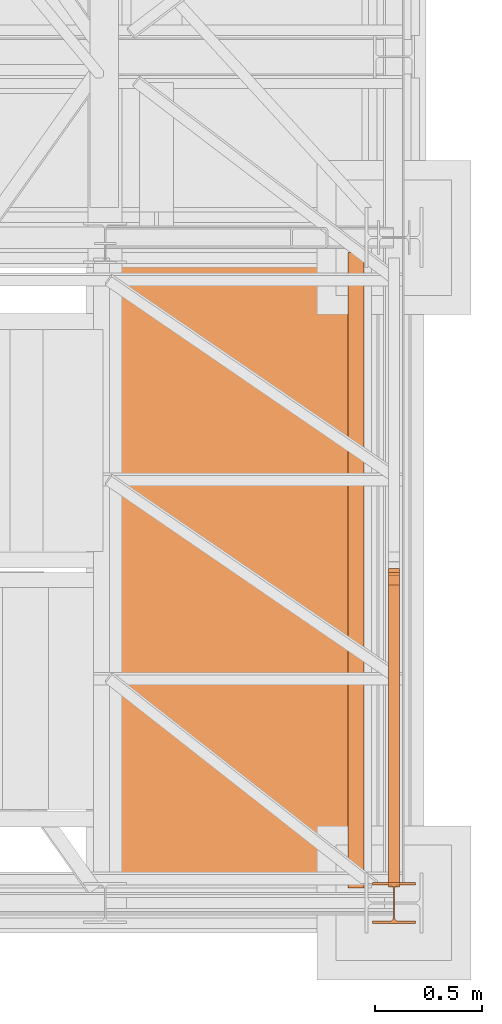
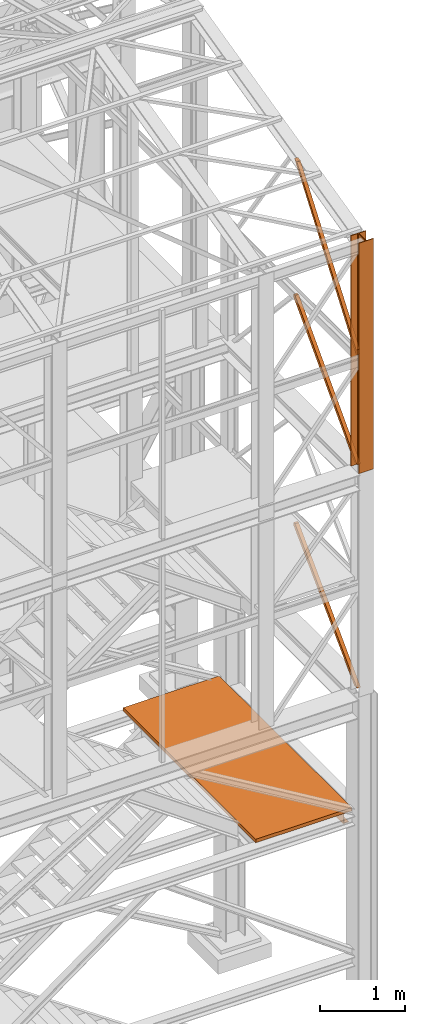
# One storey, part 50 of 208: 8 proxies.
"""IFC2X3 building model written with IfcOpenShell, lengths in millimetres."""

from ifc_helpers import new_model, entity, si_unit, converted_unit, frame, origin, origin_with_axes, place, context, subcontext, project, spatial, faceted_brep, element, save


model = new_model("IFC2X3")

# Units and contexts
model_context = context("Model", 3, precision=1e-05, world=origin())
plan_context = context("Plan", 3, precision=1e-05, world=origin())
body_context = subcontext(model_context, "Body", "Model", "MODEL_VIEW")
ifc_project = project(units=[si_unit("LENGTHUNIT", "METRE", prefix="MILLI"), converted_unit("PLANEANGLEUNIT", "DEGREE", entity("IfcPlaneAngleMeasure", 0.0174532925199433), si_unit("PLANEANGLEUNIT", "RADIAN"), dimensions=[0, 0, 0, 0, 0, 0, 0]), si_unit("AREAUNIT", "SQUARE_METRE"), si_unit("VOLUMEUNIT", "CUBIC_METRE")], contexts=[model_context, plan_context])

# Building, storey
building_placement = place(None, origin())
building = spatial("IfcBuilding", under=ifc_project, at=building_placement, CompositionType="COMPLEX")
storey_placement = place(building_placement, origin_with_axes())
storey = spatial("IfcBuildingStorey", under=building, at=storey_placement, Name="Geschoss", CompositionType="ELEMENT")

# Proxies
proxy_1_placement = place(storey_placement, frame((6483.739101185618, -25102.57439001986, 3413.989998509884), z_axis=(0.0, 0.0, 1.0), x_axis=(1.0, 0.0, 0.0)))
element("IfcBuildingElementProxy", 1, at=proxy_1_placement, inside=storey, context=body_context, shape_type="Brep", body=[
    faceted_brep([(0.01000000000021828, 2970.009999403952, 200.0100029802325), (0.01000000000021828, 2970.009999403952, 0.01000000000021828), (75.01000111758731, 2970.009999403952, 0.01000000000021828), (75.01000111758731, 2970.009999403952, 2.97083092689536), (73.89400100171588, 2970.009999403952, 7.368834147453526), (69.48847269475482, 2970.009999403952, 8.951724896431188), (19.09293180167697, 2970.009999403952, 12.98336816787742), (13.35380079060815, 2970.009999403952, 14.57858962774299), (9.50015002697728, 2970.009999403952, 18.85888857603095), (8.510000461936215, 2970.009999403952, 24.44674206733725), (8.510000461936215, 2970.009999403952, 175.5732609128954), (9.50015002697728, 2970.009999403952, 181.1611144042017), (13.35380079060815, 2970.009999403952, 185.4414133524897), (19.09293180167697, 2970.009999403952, 187.0366348123553), (69.48847269475482, 2970.009999403952, 191.0682780838015), (73.89400100171588, 2970.009999403952, 192.6511688327792), (75.01000111758731, 2970.009999403952, 197.0491720533373), (75.01000111758731, 2970.009999403952, 200.0100029802325), (0.01000000000021828, 2970.009999403952, 0.01000000000021828), (0.01000000000021828, 2970.009999403952, 200.0100029802325), (0.01000000000021828, 0.00999999999839929, 200.0100029802325), (0.01000000000021828, 0.00999999999839929, 0.01000000000021828), (75.01000111758731, 2970.009999403952, 0.01000000000021828), (0.01000000000021828, 2970.009999403952, 0.01000000000021828), (0.01000000000021828, 0.00999999999839929, 0.01000000000021828), (75.01000111758731, 0.00999999999839929, 0.01000000000021828), (75.01000111758731, 2970.009999403952, 2.97083092689536), (75.01000111758731, 2970.009999403952, 0.01000000000021828), (75.01000111758731, 0.00999999999839929, 0.01000000000021828), (75.01000111758731, 0.00999999999839929, 2.97083092689536), (73.89400100171588, 2970.009999403952, 7.368834147453526), (75.01000111758731, 2970.009999403952, 2.97083092689536), (75.01000111758731, 0.00999999999839929, 2.97083092689536), (73.89400100171588, 0.00999999999839929, 7.368834147453526), (69.48847269475482, 2970.009999403952, 8.951724896431188), (73.89400100171588, 2970.009999403952, 7.368834147453526), (73.89400100171588, 0.00999999999839929, 7.368834147453526), (69.48847269475482, 0.00999999999839929, 8.951724896431188), (19.09293180167697, 2970.009999403952, 12.98336816787742), (69.48847269475482, 2970.009999403952, 8.951724896431188), (69.48847269475482, 0.00999999999839929, 8.951724896431188), (19.09293180167697, 0.00999999999839929, 12.98336816787742), (13.35380079060815, 2970.009999403952, 14.57858962774299), (19.09293180167697, 2970.009999403952, 12.98336816787742), (19.09293180167697, 0.00999999999839929, 12.98336816787742), (13.35380079060815, 0.00999999999839929, 14.57858962774299), (9.50015002697728, 2970.009999403952, 18.85888857603095), (13.35380079060815, 2970.009999403952, 14.57858962774299), (13.35380079060815, 0.00999999999839929, 14.57858962774299), (9.50015002697728, 0.00999999999839929, 18.85888857603095), (8.510000461936215, 2970.009999403952, 24.44674206733725), (9.50015002697728, 2970.009999403952, 18.85888857603095), (9.50015002697728, 0.00999999999839929, 18.85888857603095), (8.510000461936215, 0.00999999999839929, 24.44674206733725), (8.510000461936215, 2970.009999403952, 175.5732609128954), (8.510000461936215, 2970.009999403952, 24.44674206733725), (8.510000461936215, 0.00999999999839929, 24.44674206733725), (8.510000461936215, 0.00999999999839929, 175.5732609128954), (9.50015002697728, 2970.009999403952, 181.1611144042017), (8.510000461936215, 2970.009999403952, 175.5732609128954), (8.510000461936215, 0.00999999999839929, 175.5732609128954), (9.50015002697728, 0.00999999999839929, 181.1611144042017), (13.35380079060815, 2970.009999403952, 185.4414133524897), (9.50015002697728, 2970.009999403952, 181.1611144042017), (9.50015002697728, 0.00999999999839929, 181.1611144042017), (13.35380079060815, 0.00999999999839929, 185.4414133524897), (19.09293180167697, 2970.009999403952, 187.0366348123553), (13.35380079060815, 2970.009999403952, 185.4414133524897), (13.35380079060815, 0.00999999999839929, 185.4414133524897), (19.09293180167697, 0.00999999999839929, 187.0366348123553), (69.48847269475482, 2970.009999403952, 191.0682780838015), (19.09293180167697, 2970.009999403952, 187.0366348123553), (19.09293180167697, 0.00999999999839929, 187.0366348123553), (69.48847269475482, 0.00999999999839929, 191.0682780838015), (73.89400100171588, 2970.009999403952, 192.6511688327792), (69.48847269475482, 2970.009999403952, 191.0682780838015), (69.48847269475482, 0.00999999999839929, 191.0682780838015), (73.89400100171588, 0.00999999999839929, 192.6511688327792), (75.01000111758731, 2970.009999403952, 197.0491720533373), (73.89400100171588, 2970.009999403952, 192.6511688327792), (73.89400100171588, 0.00999999999839929, 192.6511688327792), (75.01000111758731, 0.00999999999839929, 197.0491720533373), (75.01000111758731, 2970.009999403952, 200.0100029802325), (75.01000111758731, 2970.009999403952, 197.0491720533373), (75.01000111758731, 0.00999999999839929, 197.0491720533373), (75.01000111758731, 0.00999999999839929, 200.0100029802325), (0.01000000000021828, 2970.009999403952, 200.0100029802325), (75.01000111758731, 2970.009999403952, 200.0100029802325), (75.01000111758731, 0.00999999999839929, 200.0100029802325), (0.01000000000021828, 0.00999999999839929, 200.0100029802325), (0.01000000000021828, 0.00999999999839929, 200.0100029802325), (75.01000111758731, 0.00999999999839929, 200.0100029802325), (75.01000111758731, 0.00999999999839929, 197.0491720533373), (73.89400100171588, 0.00999999999839929, 192.6511688327792), (69.48847269475482, 0.00999999999839929, 191.0682780838015), (19.09293180167697, 0.00999999999839929, 187.0366348123553), (13.35380079060815, 0.00999999999839929, 185.4414133524897), (9.50015002697728, 0.00999999999839929, 181.1611144042017), (8.510000461936215, 0.00999999999839929, 175.5732609128954), (8.510000461936215, 0.00999999999839929, 24.44674206733725), (9.50015002697728, 0.00999999999839929, 18.85888857603095), (13.35380079060815, 0.00999999999839929, 14.57858962774299), (19.09293180167697, 0.00999999999839929, 12.98336816787742), (69.48847269475482, 0.00999999999839929, 8.951724896431188), (73.89400100171588, 0.00999999999839929, 7.368834147453526), (75.01000111758731, 0.00999999999839929, 2.97083092689536), (75.01000111758731, 0.00999999999839929, 0.01000000000021828), (0.01000000000021828, 0.00999999999839929, 0.01000000000021828)], [[[0, 1, 2, 3, 4, 5, 6, 7, 8, 9, 10, 11, 12, 13, 14, 15, 16, 17]], [[18, 19, 20, 21]], [[22, 23, 24, 25]], [[26, 27, 28, 29]], [[30, 31, 32, 33]], [[34, 35, 36, 37]], [[38, 39, 40, 41]], [[42, 43, 44, 45]], [[46, 47, 48, 49]], [[50, 51, 52, 53]], [[54, 55, 56, 57]], [[58, 59, 60, 61]], [[62, 63, 64, 65]], [[66, 67, 68, 69]], [[70, 71, 72, 73]], [[74, 75, 76, 77]], [[78, 79, 80, 81]], [[82, 83, 84, 85]], [[86, 87, 88, 89]], [[90, 91, 92, 93, 94, 95, 96, 97, 98, 99, 100, 101, 102, 103, 104, 105, 106, 107]]], orient=[[False], [False], [False], [False], [False], [False], [False], [False], [False], [False], [False], [False], [False], [False], [False], [False], [False], [False], [False], [False]]),
])
proxy_2_placement = place(storey_placement, frame((5258.401408260118, -25172.57439031789, 3613.990001490116), z_axis=(0.0, 0.0, 1.0), x_axis=(1.0, 0.0, 0.0)))
element("IfcBuildingElementProxy", 2, at=proxy_2_placement, inside=storey, context=body_context, shape_type="Brep", body=[
    faceted_brep([(0.009999999999308784, 0.00999999999839929, 0.01000000000021828), (1300.347694043087, 0.00999999999839929, 0.01000000000021828), (1300.347694043088, 3110.009999999998, 0.01000000000021828), (0.009999999999308784, 3110.009999999998, 0.01000000000021828), (1300.347694043087, 0.00999999999839929, 50.01000000000022), (0.009999999999308784, 0.00999999999839929, 50.01000000000022), (0.009999999999308784, 3110.009999999998, 50.01000000000022), (1300.347694043088, 3110.009999999998, 50.01000000000022), (1300.347694043087, 0.00999999999839929, 0.01000000000021828), (0.009999999999308784, 0.00999999999839929, 0.01000000000021828), (0.009999999999308784, 0.00999999999839929, 50.01000000000022), (1300.347694043087, 0.00999999999839929, 50.01000000000022), (1300.347694043088, 3110.009999999998, 0.01000000000021828), (1300.347694043087, 0.00999999999839929, 0.01000000000021828), (1300.347694043087, 0.00999999999839929, 50.01000000000022), (1300.347694043088, 3110.009999999998, 50.01000000000022), (0.009999999999308784, 3110.009999999998, 0.01000000000021828), (1300.347694043088, 3110.009999999998, 0.01000000000021828), (1300.347694043088, 3110.009999999998, 50.01000000000022), (0.009999999999308784, 3110.009999999998, 50.01000000000022), (0.009999999999308784, 0.00999999999839929, 0.01000000000021828), (0.009999999999308784, 3110.009999999998, 0.01000000000021828), (0.009999999999308784, 3110.009999999998, 50.01000000000022), (0.009999999999308784, 0.00999999999839929, 50.01000000000022)], [[[0, 1, 2, 3]], [[4, 5, 6, 7]], [[8, 9, 10, 11]], [[12, 13, 14, 15]], [[16, 17, 18, 19]], [[20, 21, 22, 23]]], orient=[[False], [False], [False], [False], [False], [False]]),
])
proxy_3_placement = place(storey_placement, frame((6598.254967038539, -25267.57439657637, 8484.990002086155), z_axis=(0.0, 0.0, 1.0), x_axis=(1.0, 0.0, 0.0)))
element("IfcBuildingElementProxy", 3, at=proxy_3_placement, inside=storey, context=body_context, shape_type="Brep", body=[
    faceted_brep([(0.01000000000021828, 190.010021192018, 3300.392426689976), (200.0100029802325, 190.010021192018, 3300.392426689976), (200.0100029802325, 180.0100232781806, 3300.392426689976), (121.2600035762789, 180.0100158276, 3300.392426689976), (111.9441915473344, 178.1454707803168, 3300.392426689976), (105.1245498640838, 171.3258277000823, 3300.392426689976), (103.2600015571716, 162.0100166024604, 3300.392426689976), (103.2600015571716, 28.01000581401968, 3300.392426689976), (105.1245498640838, 18.69419471639776, 3300.392426689976), (111.9441915473344, 11.87455163616323, 3300.392426689976), (121.2600035762789, 10.01000658888006, 3300.392426689976), (200.0100029802325, 10.01000658888006, 3300.392426689976), (200.0100029802325, 0.01000867504262715, 3300.392426689976), (0.01000000000021828, 0.01000867504262715, 3300.392426689976), (0.01000000000021828, 10.01000658888006, 3300.392426689976), (78.75999940395377, 10.01000658888006, 3300.392426689976), (88.07581143289826, 11.87455163616323, 3300.392426689976), (94.89545311614893, 18.69419471639776, 3300.392426689976), (96.76000142306111, 28.01000581401968, 3300.392426689976), (96.76000142306111, 162.0100166024604, 3300.392426689976), (94.89545311614893, 171.3258277000823, 3300.392426689976), (88.07581143289826, 178.1454707803168, 3300.392426689976), (78.75999940395377, 180.0100158276, 3300.392426689976), (0.01000000000021828, 180.0100232781806, 3300.392426689976), (200.0100029802325, 190.010021192018, 3300.392426689976), (0.01000000000021828, 190.010021192018, 3300.392426689976), (0.01000000000021828, 190.0100125169738, 0.01000000000021828), (200.0100029802325, 190.0100125169738, 0.01000000000021828), (200.0100029802325, 180.0100232781806, 3300.392426689976), (200.0100029802325, 190.010021192018, 3300.392426689976), (200.0100029802325, 190.0100125169738, 0.01000000000021828), (200.0100029802325, 180.0100146031364, 0.01000000000021828), (121.2600035762789, 180.0100158276, 3300.392426689976), (200.0100029802325, 180.0100232781806, 3300.392426689976), (200.0100029802325, 180.0100146031364, 0.01000000000021828), (121.2600035762789, 180.0100071525558, 0.01000000000021828), (111.9441915473344, 178.1454707803168, 3300.392426689976), (121.2600035762789, 180.0100158276, 3300.392426689976), (121.2600035762789, 180.0100071525558, 0.01000000000021828), (111.9441915473344, 178.1454621052726, 0.01000000000021828), (105.1245498640838, 171.3258277000823, 3300.392426689976), (111.9441915473344, 178.1454707803168, 3300.392426689976), (111.9441915473344, 178.1454621052726, 0.01000000000021828), (105.1245498640838, 171.3258190250381, 0.01000000000021828), (103.2600015571716, 162.0100166024604, 3300.392426689976), (105.1245498640838, 171.3258277000823, 3300.392426689976), (105.1245498640838, 171.3258190250381, 0.01000000000021828), (103.2600015571716, 162.0100079274162, 0.01000000000021828), (103.2600015571716, 28.01000581401968, 3300.392426689976), (103.2600015571716, 162.0100166024604, 3300.392426689976), (103.2600015571716, 162.0100079274162, 0.01000000000021828), (103.2600015571716, 28.00999713897545, 0.01000000000021828), (105.1245498640838, 18.69419471639776, 3300.392426689976), (103.2600015571716, 28.01000581401968, 3300.392426689976), (103.2600015571716, 28.00999713897545, 0.01000000000021828), (105.1245498640838, 18.69418604135353, 0.01000000000021828), (111.9441915473344, 11.87455163616323, 3300.392426689976), (105.1245498640838, 18.69419471639776, 3300.392426689976), (105.1245498640838, 18.69418604135353, 0.01000000000021828), (111.9441915473344, 11.87454296111901, 0.01000000000021828), (121.2600035762789, 10.01000658888006, 3300.392426689976), (111.9441915473344, 11.87455163616323, 3300.392426689976), (111.9441915473344, 11.87454296111901, 0.01000000000021828), (121.2600035762789, 10.00999791383583, 0.01000000000021828), (200.0100029802325, 10.01000658888006, 3300.392426689976), (121.2600035762789, 10.01000658888006, 3300.392426689976), (121.2600035762789, 10.00999791383583, 0.01000000000021828), (200.0100029802325, 10.00999791383583, 0.01000000000021828), (200.0100029802325, 0.01000867504262715, 3300.392426689976), (200.0100029802325, 10.01000658888006, 3300.392426689976), (200.0100029802325, 10.00999791383583, 0.01000000000021828), (200.0100029802325, 0.00999999999839929, 0.01000000000021828), (0.01000000000021828, 0.01000867504262715, 3300.392426689976), (200.0100029802325, 0.01000867504262715, 3300.392426689976), (200.0100029802325, 0.00999999999839929, 0.01000000000021828), (0.01000000000021828, 0.00999999999839929, 0.01000000000021828), (0.01000000000021828, 10.01000658888006, 3300.392426689976), (0.01000000000021828, 0.01000867504262715, 3300.392426689976), (0.01000000000021828, 0.00999999999839929, 0.01000000000021828), (0.01000000000021828, 10.00999791383583, 0.01000000000021828), (78.75999940395377, 10.01000658888006, 3300.392426689976), (0.01000000000021828, 10.01000658888006, 3300.392426689976), (0.01000000000021828, 10.00999791383583, 0.01000000000021828), (78.75999940395377, 10.00999791383583, 0.01000000000021828), (88.07581143289826, 11.87455163616323, 3300.392426689976), (78.75999940395377, 10.01000658888006, 3300.392426689976), (78.75999940395377, 10.00999791383583, 0.01000000000021828), (88.07581143289826, 11.87454296111901, 0.01000000000021828), (94.89545311614893, 18.69419471639776, 3300.392426689976), (88.07581143289826, 11.87455163616323, 3300.392426689976), (88.07581143289826, 11.87454296111901, 0.01000000000021828), (94.89545311614893, 18.69418604135353, 0.01000000000021828), (96.76000142306111, 28.01000581401968, 3300.392426689976), (94.89545311614893, 18.69419471639776, 3300.392426689976), (94.89545311614893, 18.69418604135353, 0.01000000000021828), (96.76000142306111, 28.00999713897545, 0.01000000000021828), (96.76000142306111, 162.0100166024604, 3300.392426689976), (96.76000142306111, 28.01000581401968, 3300.392426689976), (96.76000142306111, 28.00999713897545, 0.01000000000021828), (96.76000142306111, 162.0100079274162, 0.01000000000021828), (94.89545311614893, 171.3258277000823, 3300.392426689976), (96.76000142306111, 162.0100166024604, 3300.392426689976), (96.76000142306111, 162.0100079274162, 0.01000000000021828), (94.89545311614893, 171.3258190250381, 0.01000000000021828), (88.07581143289826, 178.1454707803168, 3300.392426689976), (94.89545311614893, 171.3258277000823, 3300.392426689976), (94.89545311614893, 171.3258190250381, 0.01000000000021828), (88.07581143289826, 178.1454621052726, 0.01000000000021828), (78.75999940395377, 180.0100158276, 3300.392426689976), (88.07581143289826, 178.1454707803168, 3300.392426689976), (88.07581143289826, 178.1454621052726, 0.01000000000021828), (78.75999940395377, 180.0100071525558, 0.01000000000021828), (0.01000000000021828, 180.0100232781806, 3300.392426689976), (78.75999940395377, 180.0100158276, 3300.392426689976), (78.75999940395377, 180.0100071525558, 0.01000000000021828), (0.01000000000021828, 180.0100146031364, 0.01000000000021828), (0.01000000000021828, 190.010021192018, 3300.392426689976), (0.01000000000021828, 180.0100232781806, 3300.392426689976), (0.01000000000021828, 180.0100146031364, 0.01000000000021828), (0.01000000000021828, 190.0100125169738, 0.01000000000021828), (0.01000000000021828, 190.0100125169738, 0.01000000000021828), (0.01000000000021828, 180.0100146031364, 0.01000000000021828), (78.75999940395377, 180.0100071525558, 0.01000000000021828), (88.07581143289826, 178.1454621052726, 0.01000000000021828), (94.89545311614893, 171.3258190250381, 0.01000000000021828), (96.76000142306111, 162.0100079274162, 0.01000000000021828), (96.76000142306111, 28.00999713897545, 0.01000000000021828), (94.89545311614893, 18.69418604135353, 0.01000000000021828), (88.07581143289826, 11.87454296111901, 0.01000000000021828), (78.75999940395377, 10.00999791383583, 0.01000000000021828), (0.01000000000021828, 10.00999791383583, 0.01000000000021828), (0.01000000000021828, 0.00999999999839929, 0.01000000000021828), (200.0100029802325, 0.00999999999839929, 0.01000000000021828), (200.0100029802325, 10.00999791383583, 0.01000000000021828), (121.2600035762789, 10.00999791383583, 0.01000000000021828), (111.9441915473344, 11.87454296111901, 0.01000000000021828), (105.1245498640838, 18.69418604135353, 0.01000000000021828), (103.2600015571716, 28.00999713897545, 0.01000000000021828), (103.2600015571716, 162.0100079274162, 0.01000000000021828), (105.1245498640838, 171.3258190250381, 0.01000000000021828), (111.9441915473344, 178.1454621052726, 0.01000000000021828), (121.2600035762789, 180.0100071525558, 0.01000000000021828), (200.0100029802325, 180.0100146031364, 0.01000000000021828), (200.0100029802325, 190.0100125169738, 0.01000000000021828)], [[[0, 1, 2, 3, 4, 5, 6, 7, 8, 9, 10, 11, 12, 13, 14, 15, 16, 17, 18, 19, 20, 21, 22, 23]], [[24, 25, 26, 27]], [[28, 29, 30, 31]], [[32, 33, 34, 35]], [[36, 37, 38, 39]], [[40, 41, 42, 43]], [[44, 45, 46, 47]], [[48, 49, 50, 51]], [[52, 53, 54, 55]], [[56, 57, 58, 59]], [[60, 61, 62, 63]], [[64, 65, 66, 67]], [[68, 69, 70, 71]], [[72, 73, 74, 75]], [[76, 77, 78, 79]], [[80, 81, 82, 83]], [[84, 85, 86, 87]], [[88, 89, 90, 91]], [[92, 93, 94, 95]], [[96, 97, 98, 99]], [[100, 101, 102, 103]], [[104, 105, 106, 107]], [[108, 109, 110, 111]], [[112, 113, 114, 115]], [[116, 117, 118, 119]], [[120, 121, 122, 123, 124, 125, 126, 127, 128, 129, 130, 131, 132, 133, 134, 135, 136, 137, 138, 139, 140, 141, 142, 143]]], orient=[[False], [False], [False], [False], [False], [False], [False], [False], [False], [False], [False], [False], [False], [False], [False], [False], [False], [False], [False], [False], [False], [False], [False], [False], [False], [False]]),
])
proxy_4_placement = place(storey_placement, frame((6673.254968156138, -25097.52533058902, 5284.990005364415), z_axis=(0.0, 0.0, 1.0), x_axis=(1.0, 0.0, 0.0)))
element("IfcBuildingElementProxy", 4, at=proxy_4_placement, inside=storey, context=body_context, shape_type="Brep", body=[
    faceted_brep([(0.01000000000021828, 1487.961249093536, 1429.098575334028), (0.009999999999308784, 63.79741231748267, 0.01000000000021828), (50.01000074505737, 63.79741231748267, 0.01000000000021828), (50.01000074505828, 1487.961249093536, 1429.098575334027), (50.01000074505828, 1455.239949618484, 1474.917439180826), (50.01000074505828, 1487.540655406407, 1475.009993890528), (50.01000074505828, 1487.961249093536, 1429.098575334027), (50.01000074505737, 63.79741231748267, 0.01000000000021828), (50.01000074505737, 0.00999999999839929, 0.01000000000021828), (0.01000000000021828, 1455.239949618484, 1474.917439180826), (50.01000074505828, 1455.239949618484, 1474.917439180826), (50.01000074505737, 0.00999999999839929, 0.01000000000021828), (0.009999999999308784, 0.00999999999839929, 0.01000000000021828), (0.01000000000021828, 1487.540655406407, 1475.009993890528), (0.01000000000021828, 1455.239949618484, 1474.917439180826), (0.009999999999308784, 0.00999999999839929, 0.01000000000021828), (0.009999999999308784, 63.79741231748267, 0.01000000000021828), (0.01000000000021828, 1487.961249093536, 1429.098575334028), (50.01000074505828, 1487.540655406407, 1475.009993890528), (50.01000074505828, 1455.239949618484, 1474.917439180826), (0.01000000000021828, 1455.239949618484, 1474.917439180826), (0.01000000000021828, 1487.540655406407, 1475.009993890528), (50.01000074505828, 1487.961249093536, 1429.098575334027), (50.01000074505828, 1487.540655406407, 1475.009993890528), (0.01000000000021828, 1487.540655406407, 1475.009993890528), (0.01000000000021828, 1487.961249093536, 1429.098575334028), (0.009999999999308784, 63.79741231748267, 0.01000000000021828), (0.009999999999308784, 0.00999999999839929, 0.01000000000021828), (50.01000074505737, 0.00999999999839929, 0.01000000000021828), (50.01000074505737, 63.79741231748267, 0.01000000000021828)], [[[0, 1, 2, 3]], [[4, 5, 6, 7, 8]], [[9, 10, 11, 12]], [[13, 14, 15, 16, 17]], [[18, 19, 20, 21]], [[22, 23, 24, 25]], [[26, 27, 28, 29]]], orient=[[False], [False], [False], [False], [False], [False], [False]]),
])
proxy_5_placement = place(storey_placement, frame((6673.254968156134, -25097.52533058902, 8484.990002086159), z_axis=(0.0, 0.0, 1.0), x_axis=(1.0, 0.0, 0.0)))
element("IfcBuildingElementProxy", 5, at=proxy_5_placement, inside=storey, context=body_context, shape_type="Brep", body=[
    faceted_brep([(0.01000000000112777, 1487.777252844244, 1497.729951931144), (0.01000000000021828, 63.79741231748267, 0.00999999999839929), (50.01000074505828, 63.79741231748267, 0.00999999999839929), (50.01000074505919, 1487.777252844244, 1497.72995193114), (50.01000074505919, 1455.239949618484, 1542.509998658894), (50.01000074505919, 1487.961138278424, 1542.602553368595), (50.01000074505919, 1487.777252844244, 1497.72995193114), (50.01000074505828, 63.79741231748267, 0.00999999999839929), (50.01000074505828, 0.00999999999839929, 0.00999999999839929), (0.01000000000112777, 1455.239949618484, 1542.509998658894), (50.01000074505919, 1455.239949618484, 1542.509998658894), (50.01000074505828, 0.00999999999839929, 0.00999999999839929), (0.01000000000021828, 0.00999999999839929, 0.00999999999839929), (0.01000000000112777, 1487.961138278424, 1542.602553368595), (0.01000000000112777, 1455.239949618484, 1542.509998658894), (0.01000000000021828, 0.00999999999839929, 0.00999999999839929), (0.01000000000021828, 63.79741231748267, 0.00999999999839929), (0.01000000000112777, 1487.777252844244, 1497.729951931144), (50.01000074505919, 1487.961138278424, 1542.602553368595), (50.01000074505919, 1455.239949618484, 1542.509998658894), (0.01000000000112777, 1455.239949618484, 1542.509998658894), (0.01000000000112777, 1487.961138278424, 1542.602553368595), (50.01000074505919, 1487.777252844244, 1497.72995193114), (50.01000074505919, 1487.961138278424, 1542.602553368595), (0.01000000000112777, 1487.961138278424, 1542.602553368595), (0.01000000000112777, 1487.777252844244, 1497.729951931144), (0.01000000000021828, 63.79741231748267, 0.00999999999839929), (0.01000000000021828, 0.00999999999839929, 0.00999999999839929), (50.01000074505828, 0.00999999999839929, 0.00999999999839929), (50.01000074505828, 63.79741231748267, 0.00999999999839929)], [[[0, 1, 2, 3]], [[4, 5, 6, 7, 8]], [[9, 10, 11, 12]], [[13, 14, 15, 16, 17]], [[18, 19, 20, 21]], [[22, 23, 24, 25]], [[26, 27, 28, 29]]], orient=[[False], [False], [False], [False], [False], [False], [False]]),
])
proxy_6_placement = place(storey_placement, frame((6673.254968156134, -25097.52533058902, 8484.990002086159), z_axis=(0.0, 0.0, 1.0), x_axis=(1.0, 0.0, 0.0)))
element("IfcBuildingElementProxy", 6, at=proxy_6_placement, inside=storey, context=body_context, shape_type="Brep", body=[
    faceted_brep([(0.01000000000112777, 1487.777252844244, 1497.729951931144), (0.01000000000021828, 63.79741231748267, 0.00999999999839929), (50.01000074505828, 63.79741231748267, 0.00999999999839929), (50.01000074505919, 1487.777252844244, 1497.72995193114), (50.01000074505919, 1455.239949618484, 1542.509998658894), (50.01000074505919, 1487.961138278424, 1542.602553368595), (50.01000074505919, 1487.777252844244, 1497.72995193114), (50.01000074505828, 63.79741231748267, 0.00999999999839929), (50.01000074505828, 0.00999999999839929, 0.00999999999839929), (0.01000000000112777, 1455.239949618484, 1542.509998658894), (50.01000074505919, 1455.239949618484, 1542.509998658894), (50.01000074505828, 0.00999999999839929, 0.00999999999839929), (0.01000000000021828, 0.00999999999839929, 0.00999999999839929), (0.01000000000112777, 1487.961138278424, 1542.602553368595), (0.01000000000112777, 1455.239949618484, 1542.509998658894), (0.01000000000021828, 0.00999999999839929, 0.00999999999839929), (0.01000000000021828, 63.79741231748267, 0.00999999999839929), (0.01000000000112777, 1487.777252844244, 1497.729951931144), (50.01000074505919, 1487.961138278424, 1542.602553368595), (50.01000074505919, 1455.239949618484, 1542.509998658894), (0.01000000000112777, 1455.239949618484, 1542.509998658894), (0.01000000000112777, 1487.961138278424, 1542.602553368595), (50.01000074505919, 1487.777252844244, 1497.72995193114), (50.01000074505919, 1487.961138278424, 1542.602553368595), (0.01000000000112777, 1487.961138278424, 1542.602553368595), (0.01000000000112777, 1487.777252844244, 1497.729951931144), (0.01000000000021828, 63.79741231748267, 0.00999999999839929), (0.01000000000021828, 0.00999999999839929, 0.00999999999839929), (50.01000074505828, 0.00999999999839929, 0.00999999999839929), (50.01000074505828, 63.79741231748267, 0.00999999999839929)], [[[0, 1, 2, 3]], [[4, 5, 6, 7, 8]], [[9, 10, 11, 12]], [[13, 14, 15, 16, 17]], [[18, 19, 20, 21]], [[22, 23, 24, 25]], [[26, 27, 28, 29]]], orient=[[False], [False], [False], [False], [False], [False], [False]]),
])
proxy_7_placement = place(storey_placement, frame((6673.254968156134, -25077.57438405939, 10042.31043759707), z_axis=(0.0, 0.0, 1.0), x_axis=(1.0, 0.0, 0.0)))
element("IfcBuildingElementProxy", 7, at=proxy_7_placement, inside=storey, context=body_context, shape_type="Brep", body=[
    faceted_brep([(50.01000074505919, 0.00999999999839929, 71.50990716364868), (0.01000000000112777, 0.00999999999839929, 71.50990716364868), (0.01000000000021828, 1392.314909891036, 1924.512375451423), (50.01000074505828, 1392.314909891036, 1924.512375451423), (50.01000074505919, 7.230990578143974, 0.1025547097015078), (50.01000074505919, 0.00999999999839929, 0.01000000000021828), (50.01000074505919, 0.00999999999839929, 71.50990716364868), (50.01000074505828, 1392.314909891036, 1924.512375451423), (50.01000074505828, 1449.983879904725, 1938.510406099498), (0.01000000000112777, 7.230990578143974, 0.1025547097015078), (50.01000074505919, 7.230990578143974, 0.1025547097015078), (50.01000074505828, 1449.983879904725, 1938.510406099498), (0.01000000000021828, 1449.983879904725, 1938.510406099496), (0.01000000000112777, 0.00999999999839929, 71.50990716364868), (0.01000000000112777, 0.00999999999839929, 0.01000000000021828), (0.01000000000112777, 7.230990578143974, 0.1025547097015078), (0.01000000000021828, 1449.983879904725, 1938.510406099496), (0.01000000000021828, 1392.314909891036, 1924.512375451423), (0.01000000000112777, 0.00999999999839929, 0.01000000000021828), (50.01000074505919, 0.00999999999839929, 0.01000000000021828), (50.01000074505919, 7.230990578143974, 0.1025547097015078), (0.01000000000112777, 7.230990578143974, 0.1025547097015078), (0.01000000000112777, 0.00999999999839929, 71.50990716364868), (50.01000074505919, 0.00999999999839929, 71.50990716364868), (50.01000074505919, 0.00999999999839929, 0.01000000000021828), (0.01000000000112777, 0.00999999999839929, 0.01000000000021828), (50.01000074505828, 1449.983879904725, 1938.510406099498), (50.01000074505828, 1392.314909891036, 1924.512375451423), (0.01000000000021828, 1392.314909891036, 1924.512375451423), (0.01000000000021828, 1449.983879904725, 1938.510406099496)], [[[0, 1, 2, 3]], [[4, 5, 6, 7, 8]], [[9, 10, 11, 12]], [[13, 14, 15, 16, 17]], [[18, 19, 20, 21]], [[22, 23, 24, 25]], [[26, 27, 28, 29]]], orient=[[False], [False], [False], [False], [False], [False], [False]]),
])
proxy_8_placement = place(storey_placement, frame((6673.254968156134, -25077.57438405939, 10042.31043759707), z_axis=(0.0, 0.0, 1.0), x_axis=(1.0, 0.0, 0.0)))
element("IfcBuildingElementProxy", 8, at=proxy_8_placement, inside=storey, context=body_context, shape_type="Brep", body=[
    faceted_brep([(50.01000074505919, 0.00999999999839929, 71.50990716364868), (0.01000000000112777, 0.00999999999839929, 71.50990716364868), (0.01000000000021828, 1392.314909891036, 1924.512375451423), (50.01000074505828, 1392.314909891036, 1924.512375451423), (50.01000074505919, 7.230990578143974, 0.1025547097015078), (50.01000074505919, 0.00999999999839929, 0.01000000000021828), (50.01000074505919, 0.00999999999839929, 71.50990716364868), (50.01000074505828, 1392.314909891036, 1924.512375451423), (50.01000074505828, 1449.983879904725, 1938.510406099498), (0.01000000000112777, 7.230990578143974, 0.1025547097015078), (50.01000074505919, 7.230990578143974, 0.1025547097015078), (50.01000074505828, 1449.983879904725, 1938.510406099498), (0.01000000000021828, 1449.983879904725, 1938.510406099496), (0.01000000000112777, 0.00999999999839929, 71.50990716364868), (0.01000000000112777, 0.00999999999839929, 0.01000000000021828), (0.01000000000112777, 7.230990578143974, 0.1025547097015078), (0.01000000000021828, 1449.983879904725, 1938.510406099496), (0.01000000000021828, 1392.314909891036, 1924.512375451423), (0.01000000000112777, 0.00999999999839929, 0.01000000000021828), (50.01000074505919, 0.00999999999839929, 0.01000000000021828), (50.01000074505919, 7.230990578143974, 0.1025547097015078), (0.01000000000112777, 7.230990578143974, 0.1025547097015078), (0.01000000000112777, 0.00999999999839929, 71.50990716364868), (50.01000074505919, 0.00999999999839929, 71.50990716364868), (50.01000074505919, 0.00999999999839929, 0.01000000000021828), (0.01000000000112777, 0.00999999999839929, 0.01000000000021828), (50.01000074505828, 1449.983879904725, 1938.510406099498), (50.01000074505828, 1392.314909891036, 1924.512375451423), (0.01000000000021828, 1392.314909891036, 1924.512375451423), (0.01000000000021828, 1449.983879904725, 1938.510406099496)], [[[0, 1, 2, 3]], [[4, 5, 6, 7, 8]], [[9, 10, 11, 12]], [[13, 14, 15, 16, 17]], [[18, 19, 20, 21]], [[22, 23, 24, 25]], [[26, 27, 28, 29]]], orient=[[False], [False], [False], [False], [False], [False], [False]]),
])

save(model, "model.ifc")
